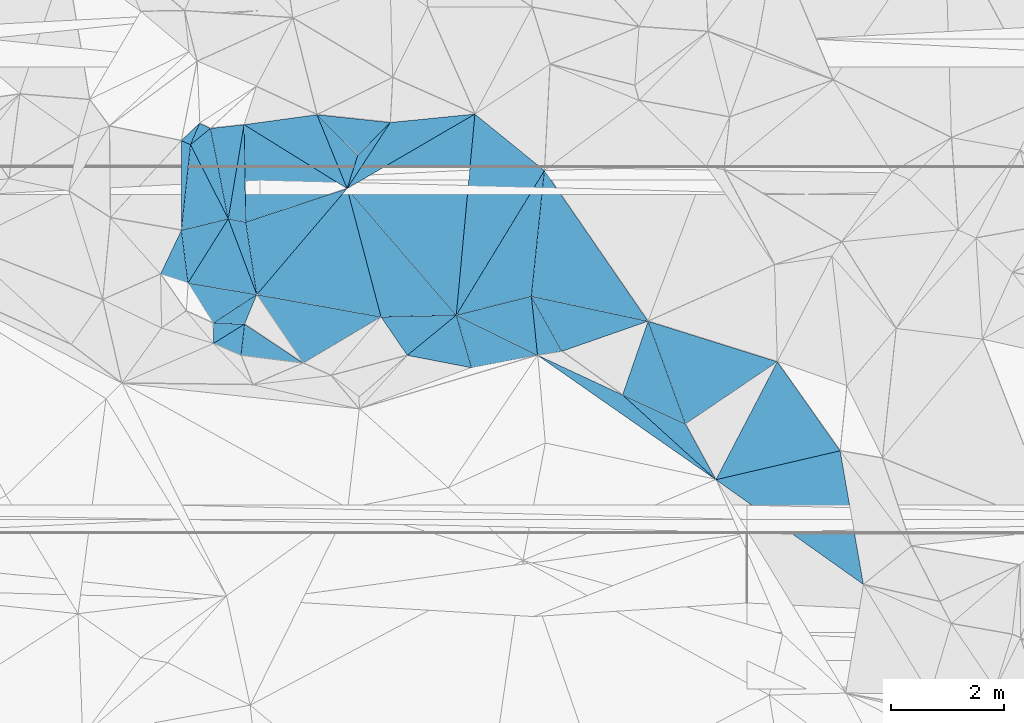
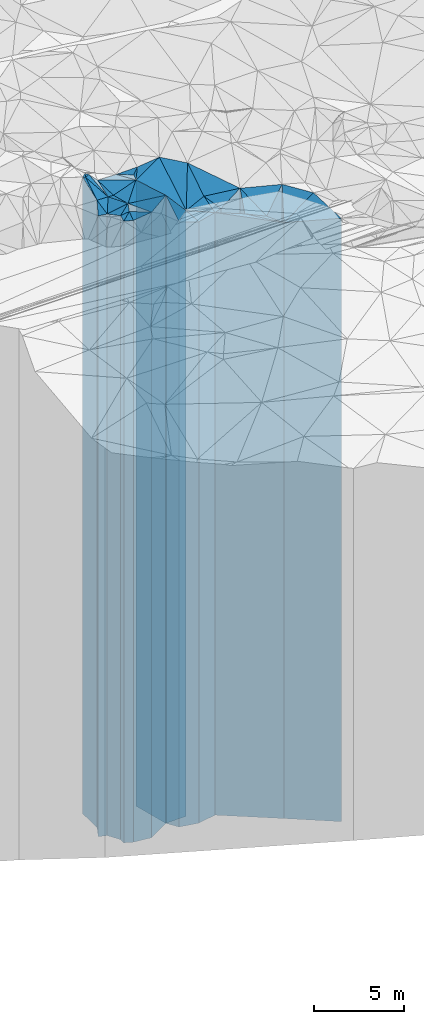
# One storey, part 204 of 275: 42 plates.
"""IFC2X3 building model written with IfcOpenShell, lengths in millimetres."""

from ifc_helpers import new_model, si_unit, frame, origin_with_axes, place, context, subcontext, project, spatial, faceted_brep, material, type_object, element, save


model = new_model("IFC2X3")

# Units and contexts
model_context = context("Model", 3, precision=1e-05, world=origin_with_axes())
body_context = subcontext(model_context, "Body", "Model", "MODEL_VIEW")
ifc_project = project(units=[si_unit("LENGTHUNIT", "METRE", prefix="MILLI"), si_unit("AREAUNIT", "SQUARE_METRE"), si_unit("VOLUMEUNIT", "CUBIC_METRE"), si_unit("MASSUNIT", "GRAM", prefix="KILO"), si_unit("TIMEUNIT", "SECOND"), si_unit("PLANEANGLEUNIT", "RADIAN"), si_unit("SOLIDANGLEUNIT", "STERADIAN"), si_unit("THERMODYNAMICTEMPERATUREUNIT", "DEGREE_CELSIUS"), si_unit("LUMINOUSINTENSITYUNIT", "LUMEN")], contexts=[model_context])

# Site, building, storey
site_placement = place(None, origin_with_axes())
site = spatial("IfcSite", under=ifc_project, at=site_placement, CompositionType="ELEMENT")
building_placement = place(site_placement, origin_with_axes())
building = spatial("IfcBuilding", under=site, at=building_placement, Name="Undefined", CompositionType="ELEMENT")
storey_placement = place(building_placement, origin_with_axes())
storey = spatial("IfcBuildingStorey", under=building, at=storey_placement, Name="Undefined", CompositionType="ELEMENT", Elevation=0.0)

# Plates
ifc_material = material()
plate_type_1 = type_object("IfcPlateType", PredefinedType="NOTDEFINED")
plate_1_placement = place(storey_placement, frame((-122580.179521868, 63798.448949693, 28064.0), z_axis=(0.945001377387409, -0.327066349134086, 0.0), x_axis=(-0.327066349134079, -0.945001377387412, 0.0)))
element("IfcPlate", 1, at=plate_1_placement, inside=storey, type_object=plate_type_1, material=ifc_material, Name="00", context=body_context, shape_type="Brep", body=[
    faceted_brep([(-3.63797880709171e-12, -21266.0, 0.0), (1501.36291503905, -20236.0, 1219.71691894531), (1501.36291503905, 20236.0, 1219.71691894531), (-3.63797880709171e-12, 20236.0, 0.0), (1379.74633789062, -20476.0, 2.53203324973583e-09), (1379.74633789062, 20236.0, 2.53203324973583e-09)], [[[0, 1, 2, 3]], [[1, 4, 5, 2]], [[4, 0, 3, 5]], [[5, 3, 2]], [[4, 1, 0]]]),
])
plate_type_2 = type_object("IfcPlateType", PredefinedType="NOTDEFINED")
plate_2_placement = place(storey_placement, frame((-121918.590619111, 61980.7305656333, 28051.0), z_axis=(-0.419212614887022, -0.907888089755332, 0.0), x_axis=(-0.907888089755331, 0.419212614887024, 0.0)))
element("IfcPlate", 2, at=plate_2_placement, inside=storey, type_object=plate_type_2, material=ifc_material, Name="00", context=body_context, shape_type="Brep", body=[
    faceted_brep([(0.0, -20249.0, 0.0), (-901.322814941377, -20223.0, 669.64709472657), (-901.322814941377, 20223.0, 669.64709472657), (0.0, 20223.0, 0.0), (1225.76501464844, -20489.0, 5.3114490583539e-10), (1225.76501464844, 20223.0, 5.3114490583539e-10)], [[[0, 1, 2, 3]], [[1, 4, 5, 2]], [[4, 0, 3, 5]], [[5, 3, 2]], [[4, 1, 0]]]),
])
plate_type_3 = type_object("IfcPlateType", PredefinedType="NOTDEFINED")
plate_3_placement = place(storey_placement, frame((-124536.073446885, 63197.1304366896, 28051.0), z_axis=(0.572357569853024, 0.820004153789443, 0.0), x_axis=(0.820004153789438, -0.572357569853031, 0.0)))
element("IfcPlate", 3, at=plate_3_placement, inside=storey, type_object=plate_type_3, material=ifc_material, Name="00", context=body_context, shape_type="Brep", body=[
    faceted_brep([(0.0, -20675.0, -7.27595761418343e-12), (1635.9052734375, -20489.0, 285.09494018554), (1635.9052734375, 20223.0, 285.09494018554), (0.0, 20223.0, 0.0), (3847.61279296875, -20223.0, 6.65750121697783e-09), (3847.61279296875, 20223.0, 6.65750121697783e-09)], [[[0, 1, 2, 3]], [[1, 4, 5, 2]], [[4, 0, 3, 5]], [[5, 3, 2]], [[4, 1, 0]]]),
])
plate_type_4 = type_object("IfcPlateType", PredefinedType="NOTDEFINED")
plate_4_placement = place(storey_placement, frame((-125973.268683841, 63905.4346445501, 28234.0), z_axis=(0.634425811662592, -0.772983757588904, 0.0), x_axis=(-0.772983757588905, -0.634425811662591, 0.0)))
element("IfcPlate", 4, at=plate_4_placement, inside=storey, type_object=plate_type_4, material=ifc_material, Name="00", context=body_context, shape_type="Brep", body=[
    faceted_brep([(-7.27595761418343e-12, -20706.0, -1.45519152283669e-11), (382.195434570305, -20406.0, 890.183471679658), (382.195434570305, 20406.0, 890.183471679658), (-7.27595761418343e-12, 20406.0, -1.45519152283669e-11), (1120.89245605467, -20676.0, -5.70435076951981e-09), (1120.89245605467, 20406.0, -5.70435076951981e-09)], [[[0, 1, 2, 3]], [[1, 4, 5, 2]], [[4, 0, 3, 5]], [[5, 3, 2]], [[4, 1, 0]]]),
])
plate_type_5 = type_object("IfcPlateType", PredefinedType="NOTDEFINED")
plate_5_placement = place(storey_placement, frame((-125703.944165359, 62974.8626141599, 28234.0), z_axis=(-0.186962959965366, 0.982366963817997, 0.0), x_axis=(0.982366963817997, 0.186962959965363, 0.0)))
element("IfcPlate", 5, at=plate_5_placement, inside=storey, type_object=plate_type_5, material=ifc_material, Name="00", context=body_context, shape_type="Brep", body=[
    faceted_brep([(0.0, -20406.0, 0.0), (-90.5930099487305, -20706.0, 964.516906738281), (-90.5930099487305, 20406.0, 964.516906738281), (-7.27595761418343e-12, 20406.0, -1.45519152283669e-11), (1188.83349609375, -20492.0, 3.63797880709171e-10), (1188.83349609375, 20406.0, 3.63797880709171e-10)], [[[0, 1, 2, 3]], [[1, 4, 5, 2]], [[4, 0, 3, 5]], [[5, 3, 2]], [[4, 1, 0]]]),
])
plate_type_6 = type_object("IfcPlateType", PredefinedType="NOTDEFINED")
plate_6_placement = place(storey_placement, frame((-129719.189282566, 63747.0715552781, 29004.0), z_axis=(-0.923352372603806, 0.383953637835251, 0.0), x_axis=(0.383953637835258, 0.923352372603803, 0.0)))
element("IfcPlate", 6, at=plate_6_placement, inside=storey, type_object=plate_type_6, material=ifc_material, Name="00", context=body_context, shape_type="Brep", body=[
    faceted_brep([(0.0, -21276.0, 0.0), (-196.867721557617, -21176.0, 518.500793457031), (-196.867721557617, 21176.0, 518.500793457031), (0.0, 21176.0, 0.0), (565.86218261718, -21426.0, -2.64844857156277e-09), (565.86218261718, 21176.0, -2.64844857156277e-09)], [[[0, 1, 2, 3]], [[1, 4, 5, 2]], [[4, 0, 3, 5]], [[5, 3, 2]], [[4, 1, 0]]]),
])
plate_type_7 = type_object("IfcPlateType", PredefinedType="NOTDEFINED")
plate_7_placement = place(storey_placement, frame((-130007.04440224, 65609.7683717455, 28924.0), z_axis=(0.2373235600808, -0.971430660330718, 0.0), x_axis=(-0.971430660330719, -0.237323560080794, 0.0)))
element("IfcPlate", 7, at=plate_7_placement, inside=storey, type_object=plate_type_7, material=ifc_material, Name="00", context=body_context, shape_type="Brep", body=[
    faceted_brep([(0.0, -21326.0, 0.0), (960.871643066392, -21096.0, 933.448303222656), (960.871643066392, 21096.0, 933.448303222656), (0.0, 21096.0, 0.0), (853.287780761704, -21506.0, 1.84809323400259e-09), (853.287780761704, 21096.0, 1.84809323400259e-09)], [[[0, 1, 2, 3]], [[1, 4, 5, 2]], [[4, 0, 3, 5]], [[5, 3, 2]], [[4, 1, 0]]]),
])
plate_type_8 = type_object("IfcPlateType", PredefinedType="NOTDEFINED")
plate_8_placement = place(storey_placement, frame((-129719.189282566, 63747.0715552781, 28929.0), z_axis=(0.993761814275988, -0.111523345030974, 0.0), x_axis=(-0.111523345030967, -0.993761814275988, 0.0)))
element("IfcPlate", 8, at=plate_8_placement, inside=storey, type_object=plate_type_8, material=ifc_material, Name="00", context=body_context, shape_type="Brep", body=[
    faceted_brep([(0.0, -21351.0, 0.0), (569.374267578118, -21361.0, 1107.79638671875), (569.374267578118, 21101.0, 1107.79638671875), (0.0, 21101.0, 0.0), (555.697753906243, -21101.0, -2.91038304567337e-10), (555.697753906243, 21101.0, -2.91038304567337e-10)], [[[0, 1, 2, 3]], [[1, 4, 5, 2]], [[4, 0, 3, 5]], [[5, 3, 2]], [[4, 1, 0]]]),
])
plate_type_9 = type_object("IfcPlateType", PredefinedType="NOTDEFINED")
plate_9_placement = place(storey_placement, frame((-126839.700381449, 63194.3115093767, 28369.0), z_axis=(-0.634425811662592, 0.772983757588904, 0.0), x_axis=(0.772983757588905, 0.634425811662591, 0.0)))
element("IfcPlate", 9, at=plate_9_placement, inside=storey, type_object=plate_type_9, material=ifc_material, Name="00", context=body_context, shape_type="Brep", body=[
    faceted_brep([(0.0, -20541.0, 0.0), (72.263839721687, -22091.0, 820.596069335938), (72.263839721687, 20541.0, 820.596069335938), (0.0, 20541.0, 0.0), (1120.89245605469, -20571.0, -5.67524693906307e-09), (1120.89245605469, 20541.0, -5.67524693906307e-09)], [[[0, 1, 2, 3]], [[1, 4, 5, 2]], [[4, 0, 3, 5]], [[5, 3, 2]], [[4, 1, 0]]]),
])
plate_type_10 = type_object("IfcPlateType", PredefinedType="NOTDEFINED")
plate_10_placement = place(storey_placement, frame((-127304.448942597, 63874.4650030168, 28384.0), z_axis=(-0.0232585060083683, 0.999729484359774, 0.0), x_axis=(0.999729484359773, 0.0232585060083723, 0.0)))
element("IfcPlate", 10, at=plate_10_placement, inside=storey, type_object=plate_type_10, material=ifc_material, Name="00", context=body_context, shape_type="Brep", body=[
    faceted_brep([(-1.45519152283669e-11, -22076.0, 0.0), (-546.810241699248, -21946.0, 2284.79736328125), (-546.810241699248, 20556.0, 2284.79736328125), (-1.45519152283669e-11, 20556.0, 0.0), (1331.54040527342, -20556.0, -3.55066731572151e-09), (1331.54040527342, 20556.0, -3.55066731572151e-09)], [[[0, 1, 2, 3]], [[1, 4, 5, 2]], [[4, 0, 3, 5]], [[5, 3, 2]], [[4, 1, 0]]]),
])
plate_type_11 = type_object("IfcPlateType", PredefinedType="NOTDEFINED")
plate_11_placement = place(storey_placement, frame((-124645.569316998, 64241.0153223107, 28277.0), z_axis=(0.994543747251122, 0.104320347026341, 0.0), x_axis=(0.104320347026342, -0.994543747251122, 0.0)))
element("IfcPlate", 11, at=plate_11_placement, inside=storey, type_object=plate_type_11, material=ifc_material, Name="00", context=body_context, shape_type="Brep", body=[
    faceted_brep([(0.0, -20963.0, 0.0), (1025.79821777344, -20533.0, 435.703918457046), (1025.79821777344, 20449.0, 435.703918457046), (0.0, 20449.0, 0.0), (1049.61181640625, -20449.0, 1.13504938781261e-09), (1049.61181640625, 20449.0, 1.13504938781261e-09)], [[[0, 1, 2, 3]], [[1, 4, 5, 2]], [[4, 0, 3, 5]], [[5, 3, 2]], [[4, 1, 0]]]),
])
plate_type_12 = type_object("IfcPlateType", PredefinedType="NOTDEFINED")
plate_12_placement = place(storey_placement, frame((-124536.073446885, 63197.1304366896, 28277.0), z_axis=(-0.994543747251122, -0.104320347026341, 0.0), x_axis=(-0.104320347026342, 0.994543747251122, 0.0)))
element("IfcPlate", 12, at=plate_12_placement, inside=storey, type_object=plate_type_12, material=ifc_material, Name="00", context=body_context, shape_type="Brep", body=[
    faceted_brep([(0.0, -20449.0, 0.0), (854.368225097656, -20663.0, 1355.46301269533), (854.368225097656, 20449.0, 1355.46301269533), (0.0, 20449.0, 0.0), (1049.61181640626, -20963.0, 1.12049747258425e-09), (1049.61181640625, 20449.0, 1.13504938781261e-09)], [[[0, 1, 2, 3]], [[1, 4, 5, 2]], [[4, 0, 3, 5]], [[5, 3, 2]], [[4, 1, 0]]]),
])
plate_type_13 = type_object("IfcPlateType", PredefinedType="NOTDEFINED")
plate_13_placement = place(storey_placement, frame((-130835.954293707, 65407.2630833528, 29039.0), z_axis=(-0.237323560080785, 0.971430660330722, 0.0), x_axis=(0.971430660330719, 0.237323560080794, 0.0)))
element("IfcPlate", 13, at=plate_13_placement, inside=storey, type_object=plate_type_13, material=ifc_material, Name="00", context=body_context, shape_type="Brep", body=[
    faceted_brep([(0.0, -21391.0, 1.45519152283669e-11), (516.12133789061, -21951.0, 1433.04528808595), (516.12133789061, 21211.0, 1433.04528808595), (0.0, 21211.0, 1.45519152283669e-11), (853.287780761719, -21211.0, 1.84809323400259e-09), (853.287780761719, 21211.0, 1.84809323400259e-09)], [[[0, 1, 2, 3]], [[1, 4, 5, 2]], [[4, 0, 3, 5]], [[5, 3, 2]], [[4, 1, 0]]]),
])
plate_type_14 = type_object("IfcPlateType", PredefinedType="NOTDEFINED")
plate_14_placement = place(storey_placement, frame((-127904.252262867, 66145.9262016716, 29054.0), z_axis=(0.315387443997098, -0.948962991991246, 0.0), x_axis=(-0.948962991991249, -0.315387443997088, 0.0)))
element("IfcPlate", 14, at=plate_14_placement, inside=storey, type_object=plate_type_14, material=ifc_material, Name="00", context=body_context, shape_type="Brep", body=[
    faceted_brep([(0.0, -21276.0, 0.0), (2107.91357421876, -21376.0, 1276.71472167969), (2107.91357421876, 21226.0, 1276.71472167969), (0.0, 21226.0, 1.45519152283669e-11), (1888.59741210938, -21226.0, -7.62520357966423e-09), (1888.59741210938, 21226.0, -7.62520357966423e-09)], [[[0, 1, 2, 3]], [[1, 4, 5, 2]], [[4, 0, 3, 5]], [[5, 3, 2]], [[4, 1, 0]]]),
])
plate_type_15 = type_object("IfcPlateType", PredefinedType="NOTDEFINED")
plate_15_placement = place(storey_placement, frame((-129501.924442219, 64269.5617361894, 29079.0), z_axis=(0.176958266951598, 0.984218355730824, 0.0), x_axis=(0.984218355730823, -0.176958266951603, 0.0)))
element("IfcPlate", 15, at=plate_15_placement, inside=storey, type_object=plate_type_15, material=ifc_material, Name="00", context=body_context, shape_type="Brep", body=[
    faceted_brep([(0.0, -21351.0, 0.0), (1240.42004394534, -21251.0, 2129.47363281251), (1240.42004394534, 21251.0, 2129.47363281251), (0.0, 21251.0, 1.45519152283669e-11), (2232.71142578125, -21381.0, -1.00262695923448e-08), (2232.71142578125, 21251.0, -1.00262695923448e-08)], [[[0, 1, 2, 3]], [[1, 4, 5, 2]], [[4, 0, 3, 5]], [[5, 3, 2]], [[4, 1, 0]]]),
])
plate_type_16 = type_object("IfcPlateType", PredefinedType="NOTDEFINED")
plate_16_placement = place(storey_placement, frame((-130718.935293339, 64474.9506070055, 28924.0), z_axis=(0.166411826040372, 0.986056339239249, 0.0), x_axis=(0.986056339239249, -0.166411826040375, 0.0)))
element("IfcPlate", 16, at=plate_16_placement, inside=storey, type_object=plate_type_16, material=ifc_material, Name="00", context=body_context, shape_type="Brep", body=[
    faceted_brep([(-7.27595761418343e-12, -21096.0, 0.0), (513.117431640654, -21326.0, 1237.46130371094), (513.117431640654, 21096.0, 1237.46130371094), (0.0, 21096.0, 0.0), (1234.2204589844, -21506.0, 3.63797880709171e-11), (1234.2204589844, 21096.0, 3.63797880709171e-11)], [[[0, 1, 2, 3]], [[1, 4, 5, 2]], [[4, 0, 3, 5]], [[5, 3, 2]], [[4, 1, 0]]]),
])
plate_type_17 = type_object("IfcPlateType", PredefinedType="NOTDEFINED")
plate_17_placement = place(storey_placement, frame((-129726.680147514, 67275.4201614878, 29039.0), z_axis=(0.986128090035565, -0.165986114005986, 0.0), x_axis=(-0.165986114005987, -0.986128090035565, 0.0)))
element("IfcPlate", 17, at=plate_17_placement, inside=storey, type_object=plate_type_17, material=ifc_material, Name="00", context=body_context, shape_type="Brep", body=[
    faceted_brep([(-7.27595761418343e-12, -21231.0, -2.91038304567337e-11), (1696.18701171874, -21241.0, 316.147949218721), (1696.18701171874, 21211.0, 316.147949218721), (0.0, 21211.0, 1.45519152283669e-11), (1689.08264160157, -21211.0, -8.17817635834217e-09), (1689.08264160157, 21211.0, -8.17817635834217e-09)], [[[0, 1, 2, 3]], [[1, 4, 5, 2]], [[4, 0, 3, 5]], [[5, 3, 2]], [[4, 1, 0]]]),
])
plate_type_18 = type_object("IfcPlateType", PredefinedType="NOTDEFINED")
plate_18_placement = place(storey_placement, frame((-130007.04440224, 65609.7683717455, 29039.0), z_axis=(-0.986128090035565, 0.165986114005986, 0.0), x_axis=(0.165986114005986, 0.986128090035565, 0.0)))
element("IfcPlate", 18, at=plate_18_placement, inside=storey, type_object=plate_type_18, material=ifc_material, Name="00", context=body_context, shape_type="Brep", body=[
    faceted_brep([(-7.27595761418343e-12, -21211.0, 2.91038304567337e-11), (1525.50268554687, -21871.0, 574.927490234404), (1525.50268554687, 21211.0, 574.927490234404), (0.0, 21211.0, 1.45519152283669e-11), (1689.08264160155, -21231.0, -8.14907252788544e-09), (1689.08264160157, 21211.0, -8.17817635834217e-09)], [[[0, 1, 2, 3]], [[1, 4, 5, 2]], [[4, 0, 3, 5]], [[5, 3, 2]], [[4, 1, 0]]]),
])
plate_type_19 = type_object("IfcPlateType", PredefinedType="NOTDEFINED")
plate_19_placement = place(storey_placement, frame((-127715.295161591, 66732.4372534663, 29034.0), z_axis=(0.951822356847927, -0.306649964951012, 0.0), x_axis=(-0.306649964951014, -0.951822356847927, 0.0)))
element("IfcPlate", 19, at=plate_19_placement, inside=storey, type_object=plate_type_19, material=ifc_material, Name="00", context=body_context, shape_type="Brep", body=[
    faceted_brep([(-1.45519152283669e-11, -21216.0, 0.0), (-729.635559082046, -21206.0, 367.738922119141), (-729.635559082046, 21206.0, 367.738922119141), (-1.45519152283669e-11, 21206.0, 0.0), (616.19799804686, -21296.0, 9.31322574615479e-10), (616.19799804686, 21206.0, 9.31322574615479e-10)], [[[0, 1, 2, 3]], [[1, 4, 5, 2]], [[4, 0, 3, 5]], [[5, 3, 2]], [[4, 1, 0]]]),
])
plate_type_20 = type_object("IfcPlateType", PredefinedType="NOTDEFINED")
plate_20_placement = place(storey_placement, frame((-127715.295161591, 66732.4372534663, 28964.0), z_axis=(-0.711955894143881, 0.702224184141921, 0.0), x_axis=(0.702224184141918, 0.711955894143884, 0.0)))
element("IfcPlate", 20, at=plate_20_placement, inside=storey, type_object=plate_type_20, material=ifc_material, Name="00", context=body_context, shape_type="Brep", body=[
    faceted_brep([(3.63797880709171e-12, -21286.0, 0.0), (4.650775909402, -21136.0, 1019.49908447269), (4.650775909402, 21136.0, 1019.49908447269), (-7.27595761418343e-12, 21136.0, 0.0), (817.067932128892, -21276.0, -6.92671164870262e-09), (817.067932128892, 21136.0, -6.92671164870262e-09)], [[[0, 1, 2, 3]], [[1, 4, 5, 2]], [[4, 0, 3, 5]], [[5, 3, 2]], [[4, 1, 0]]]),
])
plate_type_21 = type_object("IfcPlateType", PredefinedType="NOTDEFINED")
plate_21_placement = place(storey_placement, frame((-125973.268683841, 63905.4346445501, 28384.0), z_axis=(-0.245047338943694, 0.969511114777244, 0.0), x_axis=(0.969511114777243, 0.2450473389437, 0.0)))
element("IfcPlate", 21, at=plate_21_placement, inside=storey, type_object=plate_type_21, material=ifc_material, Name="00", context=body_context, shape_type="Brep", body=[
    faceted_brep([(-7.27595761418343e-12, -20556.0, 0.0), (2137.86181640622, -21696.0, 2098.86816406251), (2137.86181640622, 20556.0, 2098.86816406251), (-1.45519152283669e-11, 20556.0, 0.0), (1369.4523925781, -20856.0, 3.39059624820948e-09), (1369.4523925781, 20556.0, 3.39059624820948e-09)], [[[0, 1, 2, 3]], [[1, 4, 5, 2]], [[4, 0, 3, 5]], [[5, 3, 2]], [[4, 1, 0]]]),
])
plate_type_22 = type_object("IfcPlateType", PredefinedType="NOTDEFINED")
plate_22_placement = place(storey_placement, frame((-124414.909990113, 66464.1878920679, 28534.0), z_axis=(0.994660794445528, -0.103198372046224, 0.0), x_axis=(-0.103198372046223, -0.994660794445528, 0.0)))
element("IfcPlate", 22, at=plate_22_placement, inside=storey, type_object=plate_type_22, material=ifc_material, Name="00", context=body_context, shape_type="Brep", body=[
    faceted_brep([(0.0, -21546.0, 0.0), (2462.16479492186, -20796.0, 2100.03442382811), (2462.16479492186, 20706.0, 2100.03442382811), (2.18278728425503e-11, 20706.0, 0.0), (2235.10620117186, -20706.0, -3.53611540049315e-09), (2235.10620117186, 20706.0, -3.53611540049315e-09)], [[[0, 1, 2, 3]], [[1, 4, 5, 2]], [[4, 0, 3, 5]], [[5, 3, 2]], [[4, 1, 0]]]),
])
plate_type_23 = type_object("IfcPlateType", PredefinedType="NOTDEFINED")
plate_23_placement = place(storey_placement, frame((-119183.131620389, 61506.4267955561, 28051.0), z_axis=(0.226669496107913, -0.973971734463678, 0.0), x_axis=(-0.973971734463678, -0.226669496107912, 0.0)))
element("IfcPlate", 23, at=plate_23_placement, inside=storey, type_object=plate_type_23, material=ifc_material, Name="00", context=body_context, shape_type="Brep", body=[
    faceted_brep([(0.0, -21169.0, 0.0), (135.126922607422, -20729.0, 2397.29858398438), (135.126922607422, 20223.0, 2397.29858398438), (0.0, 20223.0, 0.0), (2256.619140625, -20223.0, -1.10157998278737e-08), (2256.619140625, 20223.0, -1.10157998278737e-08)], [[[0, 1, 2, 3]], [[1, 4, 5, 2]], [[4, 0, 3, 5]], [[5, 3, 2]], [[4, 1, 0]]]),
])
plate_type_24 = type_object("IfcPlateType", PredefinedType="NOTDEFINED")
plate_24_placement = place(storey_placement, frame((-125643.609120495, 67462.5858322697, 29034.0), z_axis=(0.098609211986361, -0.995126234862406, 0.0), x_axis=(-0.995126234862406, -0.0986092119863673, 0.0)))
element("IfcPlate", 24, at=plate_24_placement, inside=storey, type_object=plate_type_24, material=ifc_material, Name="00", context=body_context, shape_type="Brep", body=[
    faceted_brep([(0.0, -21256.0, 0.0), (2379.45996093749, -21296.0, 1087.32226562501), (2379.45996093749, 21206.0, 1087.32226562501), (-1.45519152283669e-11, 21206.0, 0.0), (1505.25744628905, -21206.0, -8.65838956087828e-09), (1505.25744628905, 21206.0, -8.65838956087828e-09)], [[[0, 1, 2, 3]], [[1, 4, 5, 2]], [[4, 0, 3, 5]], [[5, 3, 2]], [[4, 1, 0]]]),
])
plate_type_25 = type_object("IfcPlateType", PredefinedType="NOTDEFINED")
plate_25_placement = place(storey_placement, frame((-125973.268683841, 63905.4346445501, 28384.0), z_axis=(-0.854071524854, 0.520155582911077, 0.0), x_axis=(0.520155582911081, 0.854071524853998, 0.0)))
element("IfcPlate", 25, at=plate_25_placement, inside=storey, type_object=plate_type_25, material=ifc_material, Name="00", context=body_context, shape_type="Brep", body=[
    faceted_brep([(-7.27595761418343e-12, -20556.0, 0.0), (3209.5358886719, -21906.0, 1568.71923828125), (3209.5358886719, 20556.0, 1568.71923828125), (-1.45519152283669e-11, 20556.0, 0.0), (2995.94726562501, -21696.0, -3.78349795937538e-09), (2995.94726562501, 20556.0, -3.78349795937538e-09)], [[[0, 1, 2, 3]], [[1, 4, 5, 2]], [[4, 0, 3, 5]], [[5, 3, 2]], [[4, 1, 0]]]),
])
plate_type_26 = type_object("IfcPlateType", PredefinedType="NOTDEFINED")
plate_26_placement = place(storey_placement, frame((-129696.461267061, 65550.286306025, 29049.0), z_axis=(-0.315387443997098, 0.948962991991246, 0.0), x_axis=(0.948962991991249, 0.315387443997088, 0.0)))
element("IfcPlate", 26, at=plate_26_placement, inside=storey, type_object=plate_type_26, material=ifc_material, Name="00", context=body_context, shape_type="Brep", body=[
    faceted_brep([(-7.27595761418343e-12, -21231.0, -2.91038304567337e-11), (515.40893554689, -21221.0, 1646.61889648439), (515.40893554689, 21221.0, 1646.61889648439), (-1.45519152283669e-11, 21221.0, -1.45519152283669e-11), (1888.59741210938, -21281.0, -7.62520357966423e-09), (1888.59741210938, 21221.0, -7.62520357966423e-09)], [[[0, 1, 2, 3]], [[1, 4, 5, 2]], [[4, 0, 3, 5]], [[5, 3, 2]], [[4, 1, 0]]]),
])
plate_type_27 = type_object("IfcPlateType", PredefinedType="NOTDEFINED")
plate_27_placement = place(storey_placement, frame((-128437.867652229, 67451.6653089344, 28964.0), z_axis=(0.135489036943895, -0.990778845589678, 0.0), x_axis=(-0.99077884558968, -0.135489036943883, 0.0)))
element("IfcPlate", 27, at=plate_27_placement, inside=storey, type_object=plate_type_27, material=ifc_material, Name="00", context=body_context, shape_type="Brep", body=[
    faceted_brep([(2.91038304567337e-11, -21136.0, 1.45519152283669e-11), (-351.781494140596, -21366.0, 1365.99768066406), (-351.781494140596, 21136.0, 1365.99768066406), (-7.27595761418343e-12, 21136.0, 0.0), (1300.8074951172, -21306.0, 1.46974343806505e-09), (1300.8074951172, 21136.0, 1.46974343806505e-09)], [[[0, 1, 2, 3]], [[1, 4, 5, 2]], [[4, 0, 3, 5]], [[5, 3, 2]], [[4, 1, 0]]]),
])
plate_type_28 = type_object("IfcPlateType", PredefinedType="NOTDEFINED")
plate_28_placement = place(storey_placement, frame((-120294.982445827, 63081.3197258764, 28051.0), z_axis=(0.887024497134894, -0.461722364070215, 0.0), x_axis=(-0.461722364070216, -0.887024497134894, 0.0)))
element("IfcPlate", 28, at=plate_28_placement, inside=storey, type_object=plate_type_28, material=ifc_material, Name="00", context=body_context, shape_type="Brep", body=[
    faceted_brep([(-5.62749846721999e-12, -21179.0, 0.0), (883.60223388672, -21169.0, 1713.40222167969), (883.60223388672, 20223.0, 1713.40222167969), (0.0, 20223.0, 0.0), (2352.13305664063, -20223.0, 1.77533365786076e-09), (2352.13305664063, 20223.0, 1.77533365786076e-09)], [[[0, 1, 2, 3]], [[1, 4, 5, 2]], [[4, 0, 3, 5]], [[5, 3, 2]], [[4, 1, 0]]]),
])
plate_type_29 = type_object("IfcPlateType", PredefinedType="NOTDEFINED")
plate_29_placement = place(storey_placement, frame((-125643.609120495, 67462.5858322697, 28384.0), z_axis=(0.503286575950276, -0.864119564914629, 0.0), x_axis=(-0.864119564914629, -0.503286575950275, 0.0)))
element("IfcPlate", 29, at=plate_29_placement, inside=storey, type_object=plate_type_29, material=ifc_material, Name="00", context=body_context, shape_type="Brep", body=[
    faceted_brep([(0.0, -21906.0, -2.91038304567337e-11), (2075.13183593751, -20556.0, 2907.890625), (2075.13183593751, 20556.0, 2907.890625), (-1.45519152283669e-11, 20556.0, 0.0), (2616.12304687501, -21946.0, 1.45373633131385e-08), (2616.12304687501, 20556.0, 1.45373633131385e-08)], [[[0, 1, 2, 3]], [[1, 4, 5, 2]], [[4, 0, 3, 5]], [[5, 3, 2]], [[4, 1, 0]]]),
])
plate_type_30 = type_object("IfcPlateType", PredefinedType="NOTDEFINED")
plate_30_placement = place(storey_placement, frame((-130836.99521211, 66992.2233088755, 29404.0), z_axis=(0.397745432997045, 0.917495814993176, 0.0), x_axis=(0.917495814993178, -0.397745432997043, 0.0)))
element("IfcPlate", 30, at=plate_30_placement, inside=storey, type_object=plate_type_30, material=ifc_material, Name="00", context=body_context, shape_type="Brep", body=[
    faceted_brep([(-2.91038304567337e-11, -21636.0, -1.45519152283669e-11), (174.657119750977, -21576.0, 410.359466552753), (174.657119750977, 21576.0, 410.359466552753), (1.45519152283669e-11, 21576.0, 0.0), (176.918060302763, -21586.0, 3.67435859516263e-10), (176.918060302763, 21576.0, 3.67435859516263e-10)], [[[0, 1, 2, 3]], [[1, 4, 5, 2]], [[4, 0, 3, 5]], [[5, 3, 2]], [[4, 1, 0]]]),
])
plate_type_31 = type_object("IfcPlateType", PredefinedType="NOTDEFINED")
plate_31_placement = place(storey_placement, frame((-130320.784282319, 67209.5393827492, 29369.0), z_axis=(-0.421997696830674, -0.90659690263623, 0.0), x_axis=(-0.90659690263623, 0.421997696830674, 0.0)))
element("IfcPlate", 31, at=plate_31_placement, inside=storey, type_object=plate_type_31, material=ifc_material, Name="00", context=body_context, shape_type="Brep", body=[
    faceted_brep([(1.45519152283669e-11, -21541.0, 0.0), (199.432830810547, -21621.0, 410.154296874986), (199.432830810547, 21541.0, 410.154296874986), (0.0, 21541.0, -1.45519152283669e-11), (212.602920532227, -21611.0, 8.0126483226195e-10), (212.602920532227, 21541.0, 8.0126483226195e-10)], [[[0, 1, 2, 3]], [[1, 4, 5, 2]], [[4, 0, 3, 5]], [[5, 3, 2]], [[4, 1, 0]]]),
])
plate_type_32 = type_object("IfcPlateType", PredefinedType="NOTDEFINED")
plate_32_placement = place(storey_placement, frame((-129501.924442219, 64269.5617361894, 29039.0), z_axis=(-0.988659679229979, -0.150173362034934, 0.0), x_axis=(-0.150173362034932, 0.988659679229979, 0.0)))
element("IfcPlate", 32, at=plate_32_placement, inside=storey, type_object=plate_type_32, material=ifc_material, Name="00", context=body_context, shape_type="Brep", body=[
    faceted_brep([(0.0, -21391.0, 1.45519152283669e-11), (1400.86376953126, -21211.0, 298.128387451172), (1400.86376953126, 21211.0, 298.128387451172), (0.0, 21211.0, 1.45519152283669e-11), (1295.41503906251, -21241.0, -3.78349795937538e-09), (1295.41503906251, 21211.0, -3.78349795937538e-09)], [[[0, 1, 2, 3]], [[1, 4, 5, 2]], [[4, 0, 3, 5]], [[5, 3, 2]], [[4, 1, 0]]]),
])
plate_type_33 = type_object("IfcPlateType", PredefinedType="NOTDEFINED")
plate_33_placement = place(storey_placement, frame((-130835.954293707, 65407.2630833528, 29129.0), z_axis=(-0.994378281787949, 0.105885941977422, 0.0), x_axis=(0.105885941977422, 0.994378281787949, 0.0)))
element("IfcPlate", 33, at=plate_33_placement, inside=storey, type_object=plate_type_33, material=ifc_material, Name="00", context=body_context, shape_type="Brep", body=[
    faceted_brep([(0.0, -21301.0, -4.54747350886464e-12), (1575.93981933593, -21911.0, 168.860076904326), (1575.93981933593, 21301.0, 168.860076904326), (1.45519152283669e-11, 21301.0, 0.0), (1523.15466308595, -21861.0, 3.23052518069744e-09), (1523.15466308595, 21301.0, 3.23052518069744e-09)], [[[0, 1, 2, 3]], [[1, 4, 5, 2]], [[4, 0, 3, 5]], [[5, 3, 2]], [[4, 1, 0]]]),
])
plate_type_34 = type_object("IfcPlateType", PredefinedType="NOTDEFINED")
plate_34_placement = place(storey_placement, frame((-124105.231067604, 63266.2668541194, 28319.0), z_axis=(-0.329475571063494, 0.944164100181946, 0.0), x_axis=(0.944164100181946, 0.329475571063494, 0.0)))
element("IfcPlate", 34, at=plate_34_placement, inside=storey, type_object=plate_type_34, material=ifc_material, Name="00", context=body_context, shape_type="Brep", body=[
    faceted_brep([(-2.91038304567337e-11, -20491.0, 0.0), (-189.012161254883, -20921.0, 1098.35070800781), (-189.012161254883, 20491.0, 1098.35070800781), (0.0, 20491.0, 0.0), (1615.23986816406, -21011.0, 2.38651409745216e-09), (1615.23986816406, 20491.0, 2.38651409745216e-09)], [[[0, 1, 2, 3]], [[1, 4, 5, 2]], [[4, 0, 3, 5]], [[5, 3, 2]], [[4, 1, 0]]]),
])
plate_type_35 = type_object("IfcPlateType", PredefinedType="NOTDEFINED")
plate_35_placement = place(storey_placement, frame((-130320.784282319, 67209.5393827492, 29039.0), z_axis=(0.630789828075346, -0.775953731092695, 0.0), x_axis=(-0.775953731092696, -0.630789828075346, 0.0)))
element("IfcPlate", 35, at=plate_35_placement, inside=storey, type_object=plate_type_35, material=ifc_material, Name="00", context=body_context, shape_type="Brep", body=[
    faceted_brep([(-1.2732925824821e-11, -21871.0, 0.0), (765.671630859397, -21211.0, 1439.25219726563), (765.671630859397, 21211.0, 1439.25219726563), (0.0, 21211.0, 1.45519152283669e-11), (456.070159912131, -21951.0, -9.89530235528946e-10), (456.070159912131, 21211.0, -9.89530235528946e-10)], [[[0, 1, 2, 3]], [[1, 4, 5, 2]], [[4, 0, 3, 5]], [[5, 3, 2]], [[4, 1, 0]]]),
])
plate_type_36 = type_object("IfcPlateType", PredefinedType="NOTDEFINED")
plate_36_placement = place(storey_placement, frame((-129501.924442219, 64269.5617361894, 29059.0), z_axis=(0.828176731175873, 0.560467039119025, 0.0), x_axis=(0.560467039119022, -0.828176731175875, 0.0)))
element("IfcPlate", 36, at=plate_36_placement, inside=storey, type_object=plate_type_36, material=ifc_material, Name="00", context=body_context, shape_type="Brep", body=[
    faceted_brep([(-6.59383658785373e-12, -21371.0, 1.45519152283669e-11), (1558.82250976565, -21401.0, 1598.45935058594), (1558.82250976565, 21231.0, 1598.45935058594), (1.45519152283669e-11, 21231.0, 2.91038304567337e-11), (1463.2839355469, -21231.0, -2.11002770811319e-09), (1463.2839355469, 21231.0, -2.11002770811319e-09)], [[[0, 1, 2, 3]], [[1, 4, 5, 2]], [[4, 0, 3, 5]], [[5, 3, 2]], [[4, 1, 0]]]),
])
plate_type_37 = type_object("IfcPlateType", PredefinedType="NOTDEFINED")
plate_37_placement = place(storey_placement, frame((-129719.189282566, 63747.0715552781, 28924.0), z_axis=(-0.031196290009225, -0.999513277295335, 0.0), x_axis=(-0.999513277295335, 0.0311962900092148, 0.0)))
element("IfcPlate", 37, at=plate_37_placement, inside=storey, type_object=plate_type_37, material=ifc_material, Name="00", context=body_context, shape_type="Brep", body=[
    faceted_brep([(0.0, -21356.0, 0.0), (538.028930664092, -21096.0, 358.084960937493), (538.028930664092, 21096.0, 358.084960937493), (0.0, 21096.0, 0.0), (554.61700439456, -21256.0, 1.85536919161677e-09), (554.61700439456, 21096.0, 1.85536919161677e-09)], [[[0, 1, 2, 3]], [[1, 4, 5, 2]], [[4, 0, 3, 5]], [[5, 3, 2]], [[4, 1, 0]]]),
])
plate_type_38 = type_object("IfcPlateType", PredefinedType="NOTDEFINED")
plate_38_placement = place(storey_placement, frame((-130268.127294694, 63405.9453926322, 28924.0), z_axis=(0.397745432997045, 0.917495814993176, 0.0), x_axis=(0.917495814993178, -0.397745432997043, 0.0)))
element("IfcPlate", 38, at=plate_38_placement, inside=storey, type_object=plate_type_38, material=ifc_material, Name="00", context=body_context, shape_type="Brep", body=[
    faceted_brep([(-7.27595761418343e-12, -21096.0, 0.0), (367.966949462891, -21356.0, 531.319396972644), (367.966949462891, 21096.0, 531.319396972644), (0.0, 21096.0, 0.0), (530.754150390625, -21106.0, 1.07957021100447e-09), (530.754150390625, 21096.0, 1.07957021100447e-09)], [[[0, 1, 2, 3]], [[1, 4, 5, 2]], [[4, 0, 3, 5]], [[5, 3, 2]], [[4, 1, 0]]]),
])
plate_type_39 = type_object("IfcPlateType", PredefinedType="NOTDEFINED")
plate_39_placement = place(storey_placement, frame((-130718.935293339, 64474.9506070055, 28899.0), z_axis=(-0.992214884342437, -0.124537638042977, 0.0), x_axis=(-0.124537638042961, 0.99221488434244, 0.0)))
element("IfcPlate", 39, at=plate_39_placement, inside=storey, type_object=plate_type_39, material=ifc_material, Name="00", context=body_context, shape_type="Brep", body=[
    faceted_brep([(0.0, -21121.0, 2.91038304567337e-11), (216.468734741211, -21071.0, 461.672271728545), (216.468734741211, 21071.0, 461.672271728545), (0.0, 21071.0, 0.0), (939.627563476563, -21531.0, -2.3283064365387e-09), (939.627563476563, 21071.0, -2.3283064365387e-09)], [[[0, 1, 2, 3]], [[1, 4, 5, 2]], [[4, 0, 3, 5]], [[5, 3, 2]], [[4, 1, 0]]]),
])
plate_type_40 = type_object("IfcPlateType", PredefinedType="NOTDEFINED")
plate_40_placement = place(storey_placement, frame((-127715.295161591, 66732.4372534663, 28964.0), z_axis=(-0.705464661344308, -0.708745096345902, 0.0), x_axis=(-0.708745096345904, 0.705464661344306, 0.0)))
element("IfcPlate", 40, at=plate_40_placement, inside=storey, type_object=plate_type_40, material=ifc_material, Name="00", context=body_context, shape_type="Brep", body=[
    faceted_brep([(3.63797880709171e-12, -21286.0, 0.0), (-279.840393066406, -21366.0, 548.989379882805), (-279.840393066406, 21136.0, 548.989379882805), (-7.27595761418343e-12, 21136.0, 0.0), (1019.50970458984, -21136.0, -1.89902493730187e-09), (1019.50970458984, 21136.0, -1.89902493730187e-09)], [[[0, 1, 2, 3]], [[1, 4, 5, 2]], [[4, 0, 3, 5]], [[5, 3, 2]], [[4, 1, 0]]]),
])
plate_type_41 = type_object("IfcPlateType", PredefinedType="NOTDEFINED")
plate_41_placement = place(storey_placement, frame((-121918.590619111, 61980.7305656333, 28064.0), z_axis=(-0.561101668952233, 0.827746891929543, 0.0), x_axis=(0.827746891929542, 0.561101668952235, 0.0)))
element("IfcPlate", 41, at=plate_41_placement, inside=storey, type_object=plate_type_41, material=ifc_material, Name="00", context=body_context, shape_type="Brep", body=[
    faceted_brep([(0.0, -20236.0, 0.0), (472.296661376953, -21266.0, 1875.82934570313), (472.296661376953, 20236.0, 1875.82934570313), (-3.63797880709171e-12, 20236.0, 0.0), (1961.47900390624, -21166.0, 3.20142135024071e-10), (1961.47900390624, 20236.0, 3.20142135024071e-10)], [[[0, 1, 2, 3]], [[1, 4, 5, 2]], [[4, 0, 3, 5]], [[5, 3, 2]], [[4, 1, 0]]]),
])
plate_type_42 = type_object("IfcPlateType", PredefinedType="NOTDEFINED")
plate_42_placement = place(storey_placement, frame((-130273.536322835, 63764.3735477966, 28924.0), z_axis=(-0.547760231805664, 0.836635361703177, 0.0), x_axis=(0.836635361703179, 0.547760231805661, 0.0)))
element("IfcPlate", 42, at=plate_42_placement, inside=storey, type_object=plate_type_42, material=ifc_material, Name="00", context=body_context, shape_type="Brep", body=[
    faceted_brep([(0.0, -21256.0, 0.0), (16.5893268585205, -21096.0, 838.465759277344), (16.5893268585205, 21096.0, 838.465759277344), (0.0, 21096.0, 0.0), (922.27978515625, -21506.0, -2.9831426218152e-09), (922.27978515625, 21096.0, -2.9831426218152e-09)], [[[0, 1, 2, 3]], [[1, 4, 5, 2]], [[4, 0, 3, 5]], [[5, 3, 2]], [[4, 1, 0]]]),
])

save(model, "model.ifc")
